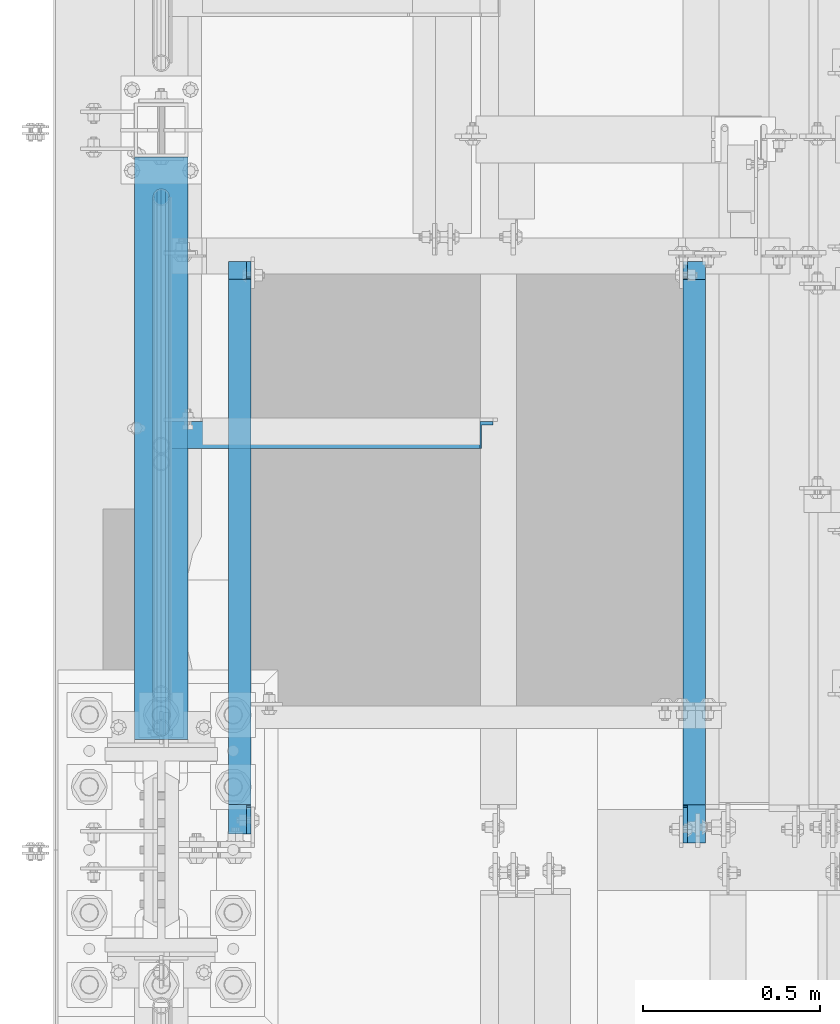
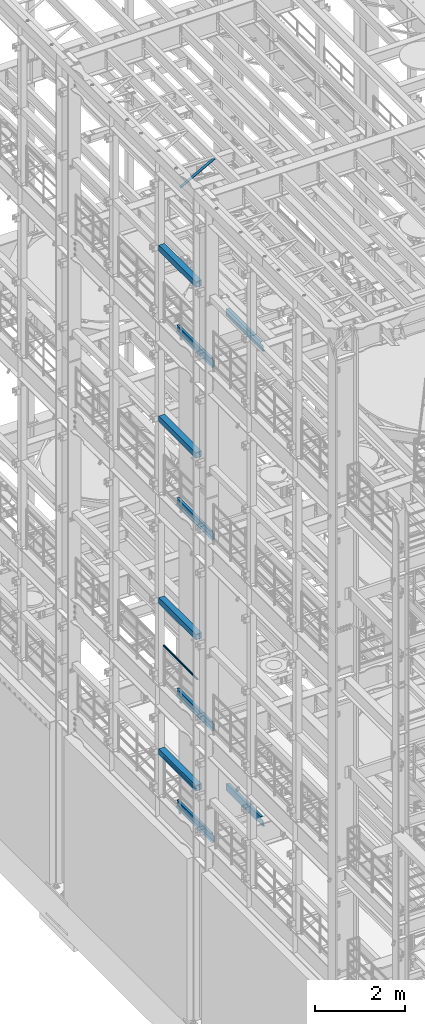
# One storey, part 1016 of 1876: 12 beams, 1 member, 13 elements without a shape of their own.
"""IFC2X3 building model written with IfcOpenShell, lengths in millimetres."""

from ifc_helpers import new_model, si_unit, frame, origin_with_axes, place, context, subcontext, project, spatial, faceted_brep, material, type_object, element, aggregate, save


model = new_model("IFC2X3")

# Units and contexts
model_context = context("Model", 3, precision=1e-05, world=origin_with_axes())
body_context = subcontext(model_context, "Body", "Model", "MODEL_VIEW")
ifc_project = project(units=[si_unit("LENGTHUNIT", "METRE", prefix="MILLI"), si_unit("AREAUNIT", "SQUARE_METRE"), si_unit("VOLUMEUNIT", "CUBIC_METRE"), si_unit("MASSUNIT", "GRAM", prefix="KILO"), si_unit("TIMEUNIT", "SECOND"), si_unit("PLANEANGLEUNIT", "RADIAN"), si_unit("SOLIDANGLEUNIT", "STERADIAN"), si_unit("THERMODYNAMICTEMPERATUREUNIT", "DEGREE_CELSIUS"), si_unit("LUMINOUSINTENSITYUNIT", "LUMEN")], contexts=[model_context])

# Site, building, storey
site_placement = place(None, origin_with_axes())
site = spatial("IfcSite", under=ifc_project, at=site_placement, CompositionType="ELEMENT")
building_placement = place(site_placement, origin_with_axes())
building = spatial("IfcBuilding", under=site, at=building_placement, Name="Undefined", CompositionType="ELEMENT")
storey_placement = place(building_placement, origin_with_axes())
storey = spatial("IfcBuildingStorey", under=building, at=storey_placement, Name="Undefined", CompositionType="ELEMENT", Elevation=0.0)

# Assembly, beam
assembly_1_placement = place(storey_placement, origin_with_axes())
assembly_1 = element("IfcElementAssembly", 1, at=assembly_1_placement, inside=storey, Name="RAIL", AssemblyPlace="NOTDEFINED", PredefinedType="RIGID_FRAME")
ifc_material_1 = material()
beam_type_1 = type_object("IfcBeamType", Name="PIPE1-1/2SCH40", PredefinedType="NOTDEFINED")
beam_1_placement = place(assembly_1_placement, frame((-1.81898940354586e-12, 1844.675, 9229.725), z_axis=(0.0, 0.0, -1.0), x_axis=(0.0, 1.0, 0.0)))
beam_1 = element("IfcBeam", 2, at=beam_1_placement, type_object=beam_type_1, material=ifc_material_1, Name="RAIL", ObjectType="PIPE1-1/2SCH40", context=body_context, shape_type="Brep", body=[
    faceted_brep([(24.1300000000001, -20.4469999999999, 0.0), (34.3535000000002, -17.7076214311803, 10.2235000000001), (1511.8715, -17.7076214311801, 10.2235000000001), (1522.095, -20.4470000000001, 0.0), (41.8376214311802, -10.2235000000001, 17.7076214311819), (1504.38737856882, -10.2235000000001, 17.7076214311819), (44.5770000000002, 0.0, 20.4470000000001), (1501.648, 0.0, 20.4470000000001), (41.8376214311802, 10.2235000000001, 17.7076214311819), (1504.38737856882, 10.2235000000001, 17.7076214311819), (34.3535000000002, 17.7076214311803, 10.2235000000001), (1511.8715, 17.7076214311801, 10.2235000000001), (24.1300000000001, 20.4469999999999, 0.0), (1522.095, 20.4470000000001, 0.0), (13.9065000000001, 17.7076214311803, -10.2235000000001), (1532.3185, 17.7076214311801, -10.2235000000001), (6.42237856882002, 10.2235000000001, -17.7076214311819), (1539.80262143118, 10.2235000000001, -17.7076214311819), (3.68299999999999, 0.0, -20.4470000000001), (1542.542, 0.0, -20.4470000000001), (6.42237856882002, -10.2235000000001, -17.7076214311819), (1539.80262143118, -10.2235000000001, -17.7076214311819), (13.9065000000001, -17.7076214311803, -10.2235000000001), (1532.3185, -17.7076214311801, -10.2235000000001), (24.1299999999854, -24.1299999999992, 0.0), (12.0650000000064, -20.8971929933177, -12.0649999999987), (1534.16, -20.8971929933186, -12.0649999999987), (1522.095, -24.1300000000001, 0.0), (3.23280700668147, -12.0650000000001, -20.8971929933177), (1542.99219299332, -12.0649999999996, -20.8971929933177), (-1.45519152283669e-11, 0.0, -24.130000000001), (1546.225, 0.0, -24.130000000001), (3.23280700668147, 12.0650000000001, -20.8971929933177), (1542.99219299332, 12.0649999999996, -20.8971929933177), (12.0650000000064, 20.8971929933177, -12.0649999999987), (1534.16, 20.8971929933186, -12.0649999999987), (24.1300000000047, 24.1299999999992, 0.0), (1522.095, 24.1300000000001, 0.0), (36.1949999999997, 20.8971929933184, 12.0649999999987), (1510.03, 20.8971929933186, 12.0649999999987), (45.0271929933187, 12.0650000000001, 20.8971929933177), (1501.19780700668, 12.0649999999996, 20.8971929933177), (48.2600000000002, 0.0, 24.130000000001), (1497.965, 0.0, 24.130000000001), (45.0271929933187, -12.0650000000001, 20.8971929933177), (1501.19780700668, -12.0649999999996, 20.8971929933177), (36.1949999999997, -20.8971929933184, 12.0649999999987), (1510.03, -20.8971929933186, 12.0649999999987)], [[[0, 1, 2, 3]], [[1, 4, 5, 2]], [[4, 6, 7, 5]], [[6, 8, 9, 7]], [[8, 10, 11, 9]], [[10, 12, 13, 11]], [[12, 14, 15, 13]], [[14, 16, 17, 15]], [[16, 18, 19, 17]], [[18, 20, 21, 19]], [[20, 22, 23, 21]], [[22, 0, 3, 23]], [[24, 25, 26, 27]], [[25, 28, 29, 26]], [[28, 30, 31, 29]], [[30, 32, 33, 31]], [[32, 34, 35, 33]], [[34, 36, 37, 35]], [[36, 38, 39, 37]], [[38, 40, 41, 39]], [[40, 42, 43, 41]], [[42, 44, 45, 43]], [[44, 46, 47, 45]], [[46, 24, 27, 47]], [[29, 31, 33, 35, 37, 39, 41, 43, 45, 47, 27, 26], [5, 7, 9, 11, 13, 15, 17, 19, 21, 23, 3, 2]], [[46, 44, 42, 40, 38, 36, 34, 32, 30, 28, 25, 24], [22, 20, 18, 16, 14, 12, 10, 8, 6, 4, 1, 0]]]),
])
aggregate(assembly_1, [beam_1])

assembly_2_placement = place(storey_placement, origin_with_axes())
assembly_2 = element("IfcElementAssembly", 3, at=assembly_2_placement, inside=storey, Name="RAIL", AssemblyPlace="NOTDEFINED", PredefinedType="RIGID_FRAME")
beam_2_placement = place(assembly_2_placement, frame((-1.81898940354586e-12, 1939.925, 6207.125), z_axis=(0.0, 0.0, -1.0), x_axis=(0.0, 1.0, 0.0)))
beam_2 = element("IfcBeam", 4, at=beam_2_placement, type_object=beam_type_1, material=ifc_material_1, Name="RAIL", ObjectType="PIPE1-1/2SCH40", context=body_context, shape_type="Brep", body=[
    faceted_brep([(24.1300000000001, -20.4469999999999, 0.0), (34.3535000000002, -17.7076214311803, 10.2235000000001), (1416.6215, -17.7076214311801, 10.2235000000001), (1426.845, -20.4470000000001, 0.0), (41.8376214311802, -10.2235000000001, 17.7076214311819), (1409.13737856882, -10.2235000000001, 17.7076214311801), (44.5770000000002, 0.0, 20.4470000000001), (1406.398, 0.0, 20.4470000000001), (41.8376214311802, 10.2235000000001, 17.7076214311819), (1409.13737856882, 10.2235000000001, 17.7076214311801), (34.3535000000002, 17.7076214311803, 10.2235000000001), (1416.6215, 17.7076214311801, 10.2235000000001), (24.1300000000001, 20.4469999999999, 0.0), (1426.845, 20.4470000000001, 0.0), (13.9065000000001, 17.7076214311803, -10.2235000000001), (1437.0685, 17.7076214311801, -10.2235000000001), (6.42237856882002, 10.2235000000001, -17.7076214311819), (1444.55262143118, 10.2235000000001, -17.7076214311801), (3.68299999999999, 0.0, -20.4470000000001), (1447.292, 0.0, -20.4470000000001), (6.42237856882002, -10.2235000000001, -17.7076214311819), (1444.55262143118, -10.2235000000001, -17.7076214311801), (13.9065000000001, -17.7076214311803, -10.2235000000001), (1437.0685, -17.7076214311801, -10.2235000000001), (24.1299999999854, -24.1299999999992, 0.0), (12.0650000000064, -20.8971929933177, -12.0649999999987), (1438.91, -20.8971929933186, -12.0649999999996), (1426.845, -24.1300000000001, 0.0), (3.23280700668147, -12.0650000000001, -20.8971929933177), (1447.74219299332, -12.0649999999996, -20.8971929933186), (-1.45519152283669e-11, 0.0, -24.130000000001), (1450.975, 0.0, -24.1300000000001), (3.23280700668147, 12.0650000000001, -20.8971929933177), (1447.74219299332, 12.0649999999996, -20.8971929933186), (12.0650000000064, 20.8971929933177, -12.0649999999987), (1438.91, 20.8971929933186, -12.0649999999996), (24.1300000000047, 24.1299999999992, 0.0), (1426.845, 24.1300000000001, 0.0), (36.1949999999997, 20.8971929933184, 12.0649999999987), (1414.78, 20.8971929933186, 12.0649999999996), (45.0271929933187, 12.0650000000001, 20.8971929933177), (1405.94780700668, 12.0649999999996, 20.8971929933186), (48.2600000000002, 0.0, 24.130000000001), (1402.715, 0.0, 24.1300000000001), (45.0271929933187, -12.0650000000001, 20.8971929933177), (1405.94780700668, -12.0649999999996, 20.8971929933186), (36.1949999999997, -20.8971929933184, 12.0649999999987), (1414.78, -20.8971929933186, 12.0649999999996)], [[[0, 1, 2, 3]], [[1, 4, 5, 2]], [[4, 6, 7, 5]], [[6, 8, 9, 7]], [[8, 10, 11, 9]], [[10, 12, 13, 11]], [[12, 14, 15, 13]], [[14, 16, 17, 15]], [[16, 18, 19, 17]], [[18, 20, 21, 19]], [[20, 22, 23, 21]], [[22, 0, 3, 23]], [[24, 25, 26, 27]], [[25, 28, 29, 26]], [[28, 30, 31, 29]], [[30, 32, 33, 31]], [[32, 34, 35, 33]], [[34, 36, 37, 35]], [[36, 38, 39, 37]], [[38, 40, 41, 39]], [[40, 42, 43, 41]], [[42, 44, 45, 43]], [[44, 46, 47, 45]], [[46, 24, 27, 47]], [[29, 31, 33, 35, 37, 39, 41, 43, 45, 47, 27, 26], [5, 7, 9, 11, 13, 15, 17, 19, 21, 23, 3, 2]], [[46, 44, 42, 40, 38, 36, 34, 32, 30, 28, 25, 24], [22, 20, 18, 16, 14, 12, 10, 8, 6, 4, 1, 0]]]),
])
aggregate(assembly_2, [beam_2])

assembly_3_placement = place(storey_placement, origin_with_axes())
assembly_3 = element("IfcElementAssembly", 5, at=assembly_3_placement, inside=storey, Name="BEAM", AssemblyPlace="NOTDEFINED", PredefinedType="RIGID_FRAME")
ifc_material_2 = material()
beam_type_2 = type_object("IfcBeamType", Name="HSS6X6X3/8", PredefinedType="NOTDEFINED")
beam_3_placement = place(assembly_3_placement, frame((0.0, 1812.925, 19958.05), z_axis=(-1.0, 0.0, 0.0), x_axis=(0.0, 1.0, 0.0)))
beam_3 = element("IfcBeam", 6, at=beam_3_placement, type_object=beam_type_2, material=ifc_material_2, Name="BEAM", ObjectType="HSS6X6X3/8", context=body_context, shape_type="Brep", body=[
    faceted_brep([(22.2249999999995, 66.6749999999993, -66.675), (22.2249999999995, -66.6749999999993, -66.675), (1666.875, -66.6749999999993, -66.675), (1666.875, 66.6749999999993, -66.675), (22.2249999999995, -66.6749999999993, 66.675), (1666.875, -66.6749999999993, 66.675), (22.2249999999995, 66.6749999999993, 66.675), (1666.875, 66.6749999999993, 66.675), (22.2249999999995, 76.2000000000007, -76.2), (22.2249999999995, 76.2000000000007, 76.2), (1666.875, 76.2000000000007, 76.2), (1666.875, 76.2000000000007, -76.2), (22.2249999999995, -76.2000000000007, 76.2), (1666.875, -76.2000000000007, 76.2), (22.2249999999995, -76.2000000000007, -76.2), (1666.875, -76.2000000000007, -76.2)], [[[0, 1, 2, 3]], [[1, 4, 5, 2]], [[4, 6, 7, 5]], [[6, 0, 3, 7]], [[8, 9, 10, 11]], [[9, 12, 13, 10]], [[12, 14, 15, 13]], [[14, 8, 11, 15]], [[13, 15, 11, 10], [5, 7, 3, 2]], [[14, 12, 9, 8], [6, 4, 1, 0]]]),
])
aggregate(assembly_3, [beam_3])

assembly_4_placement = place(storey_placement, origin_with_axes())
assembly_4 = element("IfcElementAssembly", 7, at=assembly_4_placement, inside=storey, Name="BEAM", AssemblyPlace="NOTDEFINED", PredefinedType="RIGID_FRAME")
beam_4_placement = place(assembly_4_placement, frame((0.0, 1812.925, 15335.25), z_axis=(-1.0, 0.0, 0.0), x_axis=(0.0, 1.0, 0.0)))
beam_4 = element("IfcBeam", 8, at=beam_4_placement, type_object=beam_type_2, material=ifc_material_2, Name="BEAM", ObjectType="HSS6X6X3/8", context=body_context, shape_type="Brep", body=[
    faceted_brep([(22.2249999999995, 66.6749999999993, -66.675), (22.2249999999995, -66.6749999999993, -66.675), (1666.875, -66.6749999999993, -66.675), (1666.875, 66.6749999999993, -66.675), (22.2249999999995, -66.6749999999993, 66.675), (1666.875, -66.6749999999993, 66.675), (22.2249999999995, 66.6749999999993, 66.675), (1666.875, 66.6749999999993, 66.675), (22.2249999999995, 76.2000000000007, -76.2), (22.2249999999995, 76.2000000000007, 76.2), (1666.875, 76.2000000000007, 76.2), (1666.875, 76.2000000000007, -76.2), (22.2249999999995, -76.2000000000007, 76.2), (1666.875, -76.2000000000007, 76.2), (22.2249999999995, -76.2000000000007, -76.2), (1666.875, -76.2000000000007, -76.2)], [[[0, 1, 2, 3]], [[1, 4, 5, 2]], [[4, 6, 7, 5]], [[6, 0, 3, 7]], [[8, 9, 10, 11]], [[9, 12, 13, 10]], [[12, 14, 15, 13]], [[14, 8, 11, 15]], [[13, 15, 11, 10], [5, 7, 3, 2]], [[14, 12, 9, 8], [6, 4, 1, 0]]]),
])
aggregate(assembly_4, [beam_4])

assembly_5_placement = place(storey_placement, origin_with_axes())
assembly_5 = element("IfcElementAssembly", 9, at=assembly_5_placement, inside=storey, Name="BEAM", AssemblyPlace="NOTDEFINED", PredefinedType="RIGID_FRAME")
beam_5_placement = place(assembly_5_placement, frame((0.0, 1812.925, 10420.35), z_axis=(-1.0, 0.0, 0.0), x_axis=(0.0, 1.0, 0.0)))
beam_5 = element("IfcBeam", 10, at=beam_5_placement, type_object=beam_type_2, material=ifc_material_2, Name="BEAM", ObjectType="HSS6X6X3/8", context=body_context, shape_type="Brep", body=[
    faceted_brep([(22.2249999999995, 66.6749999999993, -66.675), (22.2249999999995, -66.6749999999993, -66.675), (1666.875, -66.6749999999993, -66.675), (1666.875, 66.6749999999993, -66.675), (22.2249999999995, -66.6749999999993, 66.675), (1666.875, -66.6749999999993, 66.675), (22.2249999999995, 66.6749999999993, 66.675), (1666.875, 66.6749999999993, 66.675), (22.2249999999995, 76.2000000000007, -76.2), (22.2249999999995, 76.2000000000007, 76.2), (1666.875, 76.2000000000007, 76.2), (1666.875, 76.2000000000007, -76.2), (22.2249999999995, -76.2000000000007, 76.2), (1666.875, -76.2000000000007, 76.2), (22.2249999999995, -76.2000000000007, -76.2), (1666.875, -76.2000000000007, -76.2)], [[[0, 1, 2, 3]], [[1, 4, 5, 2]], [[4, 6, 7, 5]], [[6, 0, 3, 7]], [[8, 9, 10, 11]], [[9, 12, 13, 10]], [[12, 14, 15, 13]], [[14, 8, 11, 15]], [[13, 15, 11, 10], [5, 7, 3, 2]], [[14, 12, 9, 8], [6, 4, 1, 0]]]),
])
aggregate(assembly_5, [beam_5])

assembly_6_placement = place(storey_placement, origin_with_axes())
assembly_6 = element("IfcElementAssembly", 11, at=assembly_6_placement, inside=storey, Name="BEAM", AssemblyPlace="NOTDEFINED", PredefinedType="RIGID_FRAME")
beam_6_placement = place(assembly_6_placement, frame((0.0, 1812.925, 6330.95), z_axis=(-1.0, 0.0, 0.0), x_axis=(0.0, 1.0, 0.0)))
beam_6 = element("IfcBeam", 12, at=beam_6_placement, type_object=beam_type_2, material=ifc_material_2, Name="BEAM", ObjectType="HSS6X6X3/8", context=body_context, shape_type="Brep", body=[
    faceted_brep([(22.2249999999995, 66.6749999999993, -66.675), (22.2249999999995, -66.6749999999993, -66.675), (1666.875, -66.6749999999993, -66.675), (1666.875, 66.6749999999993, -66.675), (22.2249999999995, -66.6749999999993, 66.675), (1666.875, -66.6749999999993, 66.675), (22.2249999999995, 66.6749999999993, 66.675), (1666.875, 66.6749999999993, 66.675), (22.2249999999995, 76.2000000000007, -76.2), (22.2249999999995, 76.2000000000007, 76.2), (1666.875, 76.2000000000007, 76.2), (1666.875, 76.2000000000007, -76.2), (22.2249999999995, -76.2000000000007, 76.2), (1666.875, -76.2000000000007, 76.2), (22.2249999999995, -76.2000000000007, -76.2), (1666.875, -76.2000000000007, -76.2)], [[[0, 1, 2, 3]], [[1, 4, 5, 2]], [[4, 6, 7, 5]], [[6, 0, 3, 7]], [[8, 9, 10, 11]], [[9, 12, 13, 10]], [[12, 14, 15, 13]], [[14, 8, 11, 15]], [[13, 15, 11, 10], [5, 7, 3, 2]], [[14, 12, 9, 8], [6, 4, 1, 0]]]),
])
aggregate(assembly_6, [beam_6])

# Assembly, member
assembly_7_placement = place(storey_placement, origin_with_axes())
assembly_7 = element("IfcElementAssembly", 13, at=assembly_7_placement, inside=storey, AssemblyPlace="NOTDEFINED", PredefinedType="RIGID_FRAME")
ifc_material_3 = material(Name="STEEL/A36")
member_type = type_object("IfcMemberType", Name="L3X3X3/8", PredefinedType="NOTDEFINED")
member_placement = place(assembly_7_placement, frame((18.2754879686868, 2695.575, 22001.0692535961), z_axis=(0.0, -1.0, 0.0), x_axis=(0.877448093107104, 0.0, 0.479671600058526)))
member = element("IfcMember", 14, at=member_placement, type_object=member_type, material=ifc_material_3, ObjectType="L3X3X3/8", context=body_context, shape_type="Brep", body=[
    faceted_brep([(22.6152978728696, 38.0999999999985, -38.0999999999999), (22.6152978728696, 38.0999999999985, 38.0999999999999), (1025.78606203808, 38.1000000013628, 38.0999999999999), (1025.78606203808, 38.1000000013628, -38.0999999999999), (22.6152978728605, 28.5750000000044, 38.0999999999999), (1025.78606203807, 28.5750000013722, 38.0999999999999), (22.6152978728605, 28.5750000000044, -28.5749999999998), (1025.78606203807, 28.5750000013722, -28.5749999999998), (22.6152978728023, -38.0999999999367, -28.5749999999998), (1025.78606203801, -38.0999999985652, -28.5749999999998), (22.6152978728023, -38.0999999999367, -38.0999999999999), (1025.78606203801, -38.0999999985652, -38.0999999999999)], [[[0, 1, 2, 3]], [[1, 4, 5, 2]], [[4, 6, 7, 5]], [[6, 8, 9, 7]], [[8, 10, 11, 9]], [[10, 0, 3, 11]], [[5, 7, 9, 11, 3, 2]], [[10, 8, 6, 4, 1, 0]]]),
])
aggregate(assembly_7, [member])

# Assembly, beam
assembly_8_placement = place(storey_placement, origin_with_axes())
assembly_8 = element("IfcElementAssembly", 15, at=assembly_8_placement, inside=storey, Name="BEAM", AssemblyPlace="NOTDEFINED", PredefinedType="RIGID_FRAME")
beam_type_3 = type_object("IfcBeamType", Name="C8X18.75", PredefinedType="NOTDEFINED")
beam_7_placement = place(assembly_8_placement, frame((1504.95, 1524.0, 17881.6), z_axis=(0.0, 0.0, 1.0), x_axis=(0.0, 1.0, 0.0)))
beam_7 = element("IfcBeam", 16, at=beam_7_placement, type_object=beam_type_3, material=ifc_material_3, Name="BEAM", ObjectType="C8X18.75", context=body_context, shape_type="Brep", body=[
    faceted_brep([(114.300000190735, 19.05, 63.4999999999891), (114.300000190735, 31.75, 63.4999999999891), (19.8437500000002, 31.75, 63.4999999999891), (19.8437500000002, 19.05, 63.4999999999891), (119.16007970878, 19.05, 64.4667299225766), (119.16007970878, 31.75, 64.4667299225766), (123.280256176934, 19.05, 67.2197438230542), (123.280256176934, 31.75, 67.2197438230542), (126.033270077412, 19.05, 71.3399202912078), (126.033270077412, 31.75, 71.3399202912078), (127.0, 19.05, 76.1999998092542), (127.0, 31.75, 76.1999998092542), (127.0, -31.75, 101.599999999999), (127.0, 31.75, 101.599999999999), (127.0, 19.05, 88.9012699999985), (127.0, -31.75, 97.3645499999984), (19.8437500000002, 19.05, -88.9012699999985), (19.8437500000002, -31.75, -97.3645499999984), (1660.525, -31.75, -97.3645499999984), (1660.525, 19.05, -88.9012699999985), (19.8437500000002, -31.75, -101.599999999999), (1660.525, -31.75, -101.599999999999), (19.8437500000002, 31.75, -101.599999999999), (1660.525, 31.75, -101.599999999999), (1660.525, 31.75, 76.200000000008), (1660.525, 19.05, 76.200000000008), (1622.42499980927, 31.75, 76.200000000008), (1622.42499980927, 19.05, 76.200000000008), (1617.56492029122, 31.75, 77.1667299225956), (1617.56492029122, 19.05, 77.1667299225956), (1613.44474382307, 31.75, 79.9197438230731), (1613.44474382307, 19.05, 79.9197438230731), (1610.69172992259, 31.75, 84.0399202912267), (1610.69172992259, 19.05, 84.0399202912267), (1609.725, 31.75, 88.8999998092731), (1609.725, 19.05, 88.9012699999985), (1609.725, -31.75, 101.599999999999), (1609.725, -31.75, 97.3645499999984), (1609.725, 31.75, 101.599999999999)], [[[0, 1, 2, 3]], [[4, 5, 1, 0]], [[6, 7, 5, 4]], [[8, 9, 7, 6]], [[10, 11, 9, 8]], [[12, 13, 11, 10, 14, 15]], [[16, 17, 18, 19]], [[17, 20, 21, 18]], [[20, 22, 23, 21]], [[19, 18, 21, 23, 24, 25]], [[25, 24, 26, 27]], [[27, 26, 28, 29]], [[29, 28, 30, 31]], [[31, 30, 32, 33]], [[33, 32, 34, 35]], [[36, 37, 35, 34, 38]], [[37, 36, 12, 15]], [[35, 37, 15, 14]], [[8, 6, 4, 0, 3, 16, 19, 25, 27, 29, 31, 33, 35, 14, 10]], [[22, 20, 17, 16, 3, 2]], [[38, 34, 32, 30, 28, 26, 24, 23, 22, 2, 1, 5, 7, 9, 11, 13]], [[36, 38, 13, 12]]]),
])
aggregate(assembly_8, [beam_7])

assembly_9_placement = place(storey_placement, origin_with_axes())
assembly_9 = element("IfcElementAssembly", 17, at=assembly_9_placement, inside=storey, Name="BEAM", AssemblyPlace="NOTDEFINED", PredefinedType="RIGID_FRAME")
beam_8_placement = place(assembly_9_placement, frame((222.25, 1524.0, 17881.6), z_axis=(0.0, 0.0, -1.0), x_axis=(0.0, 1.0, 0.0)))
beam_8 = element("IfcBeam", 18, at=beam_8_placement, type_object=beam_type_3, material=ifc_material_3, Name="BEAM", ObjectType="C8X18.75", context=body_context, shape_type="Brep", body=[
    faceted_brep([(45.2437500000001, 19.05, -63.4999999999891), (45.2437500000001, 31.75, -63.4999999999891), (114.299998664856, 31.75, -63.4999999999891), (114.299998664856, 19.05, -63.4999999999891), (119.160078182901, 31.75, -64.4667299225766), (119.160078182901, 19.05, -64.4667299225766), (123.280254651055, 31.75, -67.2197438230542), (123.280254651055, 19.05, -67.2197438230542), (126.033268551533, 31.75, -71.3399202912078), (126.033268551533, 19.05, -71.3399202912078), (126.999998474121, 19.05, -76.1999998092542), (126.999998474121, 31.75, -76.1999998092542), (126.999998474121, 31.75, -101.599999999999), (126.999998474121, -31.75, -101.599999999999), (126.999998474121, -31.75, -97.3645499999984), (126.999998474121, 19.05, -88.9012699999985), (45.2437500000001, 31.75, 101.599999999999), (45.2437500000001, -31.75, 101.599999999999), (1660.525, -31.75, 101.599999999999), (1660.525, 31.75, 101.599999999999), (45.2437500000001, -31.75, 97.3645499999984), (1660.525, -31.75, 97.3645499999984), (45.2437500000001, 19.05, 88.9012699999985), (1660.525, 19.05, 88.9012699999985), (1660.525, 19.05, -76.200000000008), (1660.525, 31.75, -76.200000000008), (1625.59999980927, 19.05, -76.200000000008), (1625.59999980927, 31.75, -76.200000000008), (1620.73992029122, 19.05, -77.1667299225956), (1620.73992029122, 31.75, -77.1667299225956), (1616.61974382307, 19.05, -79.9197438230731), (1616.61974382307, 31.75, -79.9197438230731), (1613.86672992259, 19.05, -84.0399202912267), (1613.86672992259, 31.75, -84.0399202912267), (1612.9, 19.05, -88.9012699999985), (1612.9, 31.75, -88.8999998092731), (1612.9, -31.75, -97.3645499999984), (1612.9, -31.75, -101.599999999999), (1612.9, 31.75, -101.599999999999)], [[[0, 1, 2, 3]], [[3, 2, 4, 5]], [[5, 4, 6, 7]], [[7, 6, 8, 9]], [[10, 11, 12, 13, 14, 15]], [[9, 8, 11, 10]], [[16, 17, 18, 19]], [[17, 20, 21, 18]], [[20, 22, 23, 21]], [[19, 18, 21, 23, 24, 25]], [[24, 26, 27, 25]], [[28, 29, 27, 26]], [[30, 31, 29, 28]], [[32, 33, 31, 30]], [[34, 35, 33, 32]], [[36, 37, 38, 35, 34]], [[36, 34, 15, 14]], [[37, 36, 14, 13]], [[38, 37, 13, 12]], [[6, 4, 2, 1, 16, 19, 25, 27, 29, 31, 33, 35, 38, 12, 11, 8]], [[22, 20, 17, 16, 1, 0]], [[34, 32, 30, 28, 26, 24, 23, 22, 0, 3, 5, 7, 9, 10, 15]]]),
])
aggregate(assembly_9, [beam_8])

assembly_10_placement = place(storey_placement, origin_with_axes())
assembly_10 = element("IfcElementAssembly", 19, at=assembly_10_placement, inside=storey, Name="BEAM", AssemblyPlace="NOTDEFINED", PredefinedType="RIGID_FRAME")
beam_9_placement = place(assembly_10_placement, frame((222.25, 1524.0, 13208.0), z_axis=(0.0, 0.0, -1.0), x_axis=(0.0, 1.0, 0.0)))
beam_9 = element("IfcBeam", 20, at=beam_9_placement, type_object=beam_type_3, material=ifc_material_3, Name="BEAM", ObjectType="C8X18.75", context=body_context, shape_type="Brep", body=[
    faceted_brep([(115.093750190735, 19.0499999999993, -63.5000000000036), (115.093750190735, 31.75, -63.5000000000036), (119.953829708781, 31.75, -64.4667299225912), (119.953829708781, 19.0499999999993, -64.4667299225912), (124.074006176934, 31.75, -67.2197438230687), (124.074006176934, 19.0499999999993, -67.2197438230687), (126.827020077413, 31.75, -71.3399202912224), (126.827020077413, 19.0499999999993, -71.3399202912224), (127.79375, 31.75, -76.1999998092688), (127.79375, 19.0499999999993, -76.1999998092688), (127.79375, -31.75, -97.3645499999984), (127.79375, -31.75, -101.599999999999), (1609.725, -31.75, -101.6), (1609.725, -31.75, -97.3645500000002), (127.793750000001, 19.05, -88.9012700000003), (1609.725, -19.0576219043606, -95.2499998092662), (1610.69172992259, 10.1145240623, -90.3899202912216), (1611.68641424652, 19.05, -88.9012700000003), (127.79375, 31.75, -101.599999999999), (1609.725, 31.75, -101.6), (1609.725, 31.75, -95.2499998092662), (1610.69172992259, 31.75, -90.3899202912216), (1613.44474382307, 31.75, -86.2697438230662), (1613.44474382307, 19.05, -86.2697438230662), (1617.56492029122, 31.75, -83.5167299225886), (1617.56492029122, 19.05, -83.5167299225886), (1622.42499980927, 31.75, -82.5500000000011), (1622.42499980927, 19.05, -82.5500000000011), (1660.525, 19.05, -82.5500000000011), (1660.525, 31.75, -82.5500000000011), (1660.525, 31.75, 101.599999999999), (1660.525, -31.75, 101.599999999999), (1660.525, -31.75, 97.3645499999984), (1660.525, 19.05, 88.9012699999985), (45.2437500000001, -31.75, 101.599999999999), (45.2437500000001, -31.75, 97.3645499999984), (45.2437500000001, 19.05, 88.9012699999985), (45.2437500000001, 19.05, -63.4999999999891), (45.2437500000001, 31.75, -63.4999999999891), (45.2437500000001, 31.75, 101.599999999999)], [[[0, 1, 2, 3]], [[3, 2, 4, 5]], [[5, 4, 6, 7]], [[7, 6, 8, 9]], [[10, 11, 12, 13]], [[14, 10, 13, 15, 16, 17]], [[9, 8, 18, 11, 10, 14]], [[11, 18, 19, 12]], [[13, 12, 19, 20, 15]], [[15, 20, 21, 16]], [[17, 16, 21, 22, 23]], [[23, 22, 24, 25]], [[25, 24, 26, 27]], [[28, 27, 26, 29]], [[30, 31, 32, 33, 28, 29]], [[34, 35, 32, 31]], [[35, 36, 33, 32]], [[0, 3, 5, 7, 9, 14, 17, 23, 25, 27, 28, 33, 36, 37]], [[1, 0, 37, 38]], [[30, 29, 26, 24, 22, 21, 20, 19, 18, 8, 6, 4, 2, 1, 38, 39]], [[39, 34, 31, 30]], [[36, 35, 34, 39, 38, 37]]]),
])
aggregate(assembly_10, [beam_9])

assembly_11_placement = place(storey_placement, origin_with_axes())
assembly_11 = element("IfcElementAssembly", 21, at=assembly_11_placement, inside=storey, Name="BEAM", AssemblyPlace="NOTDEFINED", PredefinedType="RIGID_FRAME")
beam_10_placement = place(assembly_11_placement, frame((222.25, 1524.0, 8051.8), z_axis=(0.0, 0.0, -1.0), x_axis=(0.0, 1.0, 0.0)))
beam_10 = element("IfcBeam", 22, at=beam_10_placement, type_object=beam_type_3, material=ifc_material_3, Name="BEAM", ObjectType="C8X18.75", context=body_context, shape_type="Brep", body=[
    faceted_brep([(115.093750190735, 19.0499999999993, -63.5000000000036), (115.093750190735, 31.75, -63.5000000000036), (119.953829708781, 31.75, -64.4667299225912), (119.953829708781, 19.0499999999993, -64.4667299225912), (124.074006176934, 31.75, -67.2197438230687), (124.074006176934, 19.0499999999993, -67.2197438230687), (126.827020077413, 31.75, -71.3399202912224), (126.827020077413, 19.0499999999993, -71.3399202912224), (127.79375, 31.75, -76.1999998092688), (127.79375, 19.0499999999993, -76.1999998092688), (127.79375, -31.75, -97.3645499999984), (127.79375, -31.75, -101.599999999999), (1609.725, -31.75, -101.6), (1609.725, -31.75, -97.3645500000002), (127.793750000001, 19.05, -88.9012700000003), (1609.725, -19.0576219043606, -95.2499998092662), (1610.69172992259, 10.1145240623, -90.3899202912216), (1611.68641424652, 19.05, -88.9012700000003), (127.79375, 31.75, -101.599999999999), (1609.725, 31.75, -101.6), (1609.725, 31.75, -95.2499998092662), (1610.69172992259, 31.75, -90.3899202912216), (1613.44474382307, 31.75, -86.2697438230662), (1613.44474382307, 19.05, -86.2697438230662), (1617.56492029122, 31.75, -83.5167299225886), (1617.56492029122, 19.05, -83.5167299225886), (1622.42499980927, 31.75, -82.5500000000011), (1622.42499980927, 19.05, -82.5500000000011), (1660.525, 19.05, -82.5500000000011), (1660.525, 31.75, -82.5500000000011), (1660.525, 31.75, 101.599999999999), (1660.525, -31.75, 101.599999999999), (1660.525, -31.75, 97.3645499999984), (1660.525, 19.05, 88.9012699999985), (45.2437500000001, -31.75, 101.599999999999), (45.2437500000001, -31.75, 97.3645499999984), (45.2437500000001, 19.05, 88.9012699999985), (45.2437500000001, 19.05, -63.4999999999891), (45.2437500000001, 31.75, -63.4999999999891), (45.2437500000001, 31.75, 101.599999999999)], [[[0, 1, 2, 3]], [[3, 2, 4, 5]], [[5, 4, 6, 7]], [[7, 6, 8, 9]], [[10, 11, 12, 13]], [[14, 10, 13, 15, 16, 17]], [[9, 8, 18, 11, 10, 14]], [[11, 18, 19, 12]], [[13, 12, 19, 20, 15]], [[15, 20, 21, 16]], [[17, 16, 21, 22, 23]], [[23, 22, 24, 25]], [[25, 24, 26, 27]], [[28, 27, 26, 29]], [[30, 31, 32, 33, 28, 29]], [[34, 35, 32, 31]], [[35, 36, 33, 32]], [[0, 3, 5, 7, 9, 14, 17, 23, 25, 27, 28, 33, 36, 37]], [[1, 0, 37, 38]], [[30, 29, 26, 24, 22, 21, 20, 19, 18, 8, 6, 4, 2, 1, 38, 39]], [[39, 34, 31, 30]], [[36, 35, 34, 39, 38, 37]]]),
])
aggregate(assembly_11, [beam_10])

assembly_12_placement = place(storey_placement, origin_with_axes())
assembly_12 = element("IfcElementAssembly", 23, at=assembly_12_placement, inside=storey, Name="BEAM", AssemblyPlace="NOTDEFINED", PredefinedType="RIGID_FRAME")
beam_11_placement = place(assembly_12_placement, frame((1504.95, 1524.0, 5029.2), z_axis=(0.0, 0.0, 1.0), x_axis=(0.0, 1.0, 0.0)))
beam_11 = element("IfcBeam", 24, at=beam_11_placement, type_object=beam_type_3, material=ifc_material_3, Name="BEAM", ObjectType="C8X18.75", context=body_context, shape_type="Brep", body=[
    faceted_brep([(1609.725, -31.75, 101.599999999999), (1609.725, -31.75, 97.3645499999984), (1609.725, -19.0576219043483, 95.2499998092644), (1609.725, 31.75, 95.2499998092644), (1609.725, 31.75, 101.599999999999), (1610.69172992259, 10.1145240623116, 90.3899202912189), (1610.69172992259, 31.75, 90.3899202912189), (1613.44474382307, 19.05, 86.2697438230653), (1613.44474382307, 31.75, 86.2697438230653), (1611.68641424652, 19.05, 88.9012700000003), (1617.56492029122, 19.05, 83.5167299225868), (1617.56492029122, 31.75, 83.5167299225868), (1622.42499980927, 19.05, 82.5499999999993), (1622.42499980927, 31.75, 82.5499999999993), (1660.525, 19.05, 82.5499999999993), (1660.525, 31.75, 82.5499999999993), (127.79375, -31.75, 101.599999999999), (127.79375, 31.75, 101.599999999999), (127.79375, 31.75, 76.1999998092688), (127.79375, 19.0499999999993, 76.1999998092688), (127.79375, 19.0499999999993, 88.9012699999985), (127.79375, -31.75, 97.3645499999984), (126.827020077412, 31.75, 71.3399202912224), (126.827020077412, 19.0499999999993, 71.3399202912224), (124.074006176934, 31.75, 67.2197438230687), (124.074006176934, 19.0499999999993, 67.2197438230687), (119.953829708781, 31.75, 64.4667299225912), (119.953829708781, 19.0499999999993, 64.4667299225912), (115.093750190735, 31.75, 63.5000000000036), (115.093750190735, 19.0499999999993, 63.5000000000036), (19.8437500000002, 31.75, 63.4999999999891), (19.8437500000002, 19.05, 63.4999999999891), (19.8437500000002, 31.75, -101.599999999999), (19.8437500000002, -31.75, -101.599999999999), (19.8437500000002, -31.75, -97.3645499999984), (19.8437500000002, 19.05, -88.9012699999985), (1660.525, 31.75, -101.599999999999), (1660.525, -31.75, -101.599999999999), (1660.525, -31.75, -97.3645499999984), (1660.525, 19.05, -88.9012699999985)], [[[0, 1, 2, 3, 4]], [[5, 6, 3, 2]], [[7, 8, 6, 5, 9]], [[10, 11, 8, 7]], [[12, 13, 11, 10]], [[14, 15, 13, 12]], [[16, 17, 18, 19, 20, 21]], [[19, 18, 22, 23]], [[23, 22, 24, 25]], [[25, 24, 26, 27]], [[27, 26, 28, 29]], [[29, 28, 30, 31]], [[32, 33, 34, 35, 31, 30]], [[33, 32, 36, 37]], [[34, 33, 37, 38]], [[35, 34, 38, 39]], [[10, 7, 9, 20, 19, 23, 25, 27, 29, 31, 35, 39, 14, 12]], [[2, 1, 21, 20, 9, 5]], [[16, 21, 1, 0]], [[17, 16, 0, 4]], [[36, 32, 30, 28, 26, 24, 22, 18, 17, 4, 3, 6, 8, 11, 13, 15]], [[39, 38, 37, 36, 15, 14]]]),
])
aggregate(assembly_12, [beam_11])

assembly_13_placement = place(storey_placement, origin_with_axes())
assembly_13 = element("IfcElementAssembly", 25, at=assembly_13_placement, inside=storey, Name="BEAM", AssemblyPlace="NOTDEFINED", PredefinedType="RIGID_FRAME")
beam_12_placement = place(assembly_13_placement, frame((222.25, 1524.0, 5029.2), z_axis=(0.0, 0.0, -1.0), x_axis=(0.0, 1.0, 0.0)))
beam_12 = element("IfcBeam", 26, at=beam_12_placement, type_object=beam_type_3, material=ifc_material_3, Name="BEAM", ObjectType="C8X18.75", context=body_context, shape_type="Brep", body=[
    faceted_brep([(115.093750190735, 19.0499999999993, -63.5000000000036), (115.093750190735, 31.75, -63.5000000000036), (119.953829708781, 31.75, -64.4667299225912), (119.953829708781, 19.0499999999993, -64.4667299225912), (124.074006176934, 31.75, -67.2197438230687), (124.074006176934, 19.0499999999993, -67.2197438230687), (126.827020077413, 31.75, -71.3399202912224), (126.827020077413, 19.0499999999993, -71.3399202912224), (127.79375, 31.75, -76.1999998092688), (127.79375, 19.0499999999993, -76.1999998092688), (127.79375, -31.75, -97.3645499999984), (127.79375, -31.75, -101.599999999999), (1609.725, -31.75, -101.6), (1609.725, -31.75, -97.3645500000002), (127.793750000001, 19.05, -88.9012700000003), (1609.725, -19.0576219043606, -95.2499998092662), (1610.69172992259, 10.1145240623, -90.3899202912216), (1611.68641424652, 19.05, -88.9012700000003), (127.79375, 31.75, -101.599999999999), (1609.725, 31.75, -101.6), (1609.725, 31.75, -95.2499998092662), (1610.69172992259, 31.75, -90.3899202912216), (1613.44474382307, 31.75, -86.2697438230662), (1613.44474382307, 19.05, -86.2697438230662), (1617.56492029122, 31.75, -83.5167299225886), (1617.56492029122, 19.05, -83.5167299225886), (1622.42499980927, 31.75, -82.5500000000011), (1622.42499980927, 19.05, -82.5500000000011), (1660.525, 19.05, -82.5500000000011), (1660.525, 31.75, -82.5500000000011), (1660.525, 31.75, 101.599999999999), (1660.525, -31.75, 101.599999999999), (1660.525, -31.75, 97.3645499999984), (1660.525, 19.05, 88.9012699999985), (45.2437500000001, -31.75, 101.599999999999), (45.2437500000001, -31.75, 97.3645499999984), (45.2437500000001, 19.05, 88.9012699999985), (45.2437500000001, 19.05, -63.4999999999891), (45.2437500000001, 31.75, -63.4999999999891), (45.2437500000001, 31.75, 101.599999999999)], [[[0, 1, 2, 3]], [[3, 2, 4, 5]], [[5, 4, 6, 7]], [[7, 6, 8, 9]], [[10, 11, 12, 13]], [[14, 10, 13, 15, 16, 17]], [[9, 8, 18, 11, 10, 14]], [[11, 18, 19, 12]], [[13, 12, 19, 20, 15]], [[15, 20, 21, 16]], [[17, 16, 21, 22, 23]], [[23, 22, 24, 25]], [[25, 24, 26, 27]], [[28, 27, 26, 29]], [[30, 31, 32, 33, 28, 29]], [[34, 35, 32, 31]], [[35, 36, 33, 32]], [[0, 3, 5, 7, 9, 14, 17, 23, 25, 27, 28, 33, 36, 37]], [[1, 0, 37, 38]], [[30, 29, 26, 24, 22, 21, 20, 19, 18, 8, 6, 4, 2, 1, 38, 39]], [[39, 34, 31, 30]], [[36, 35, 34, 39, 38, 37]]]),
])
aggregate(assembly_13, [beam_12])

save(model, "model.ifc")
